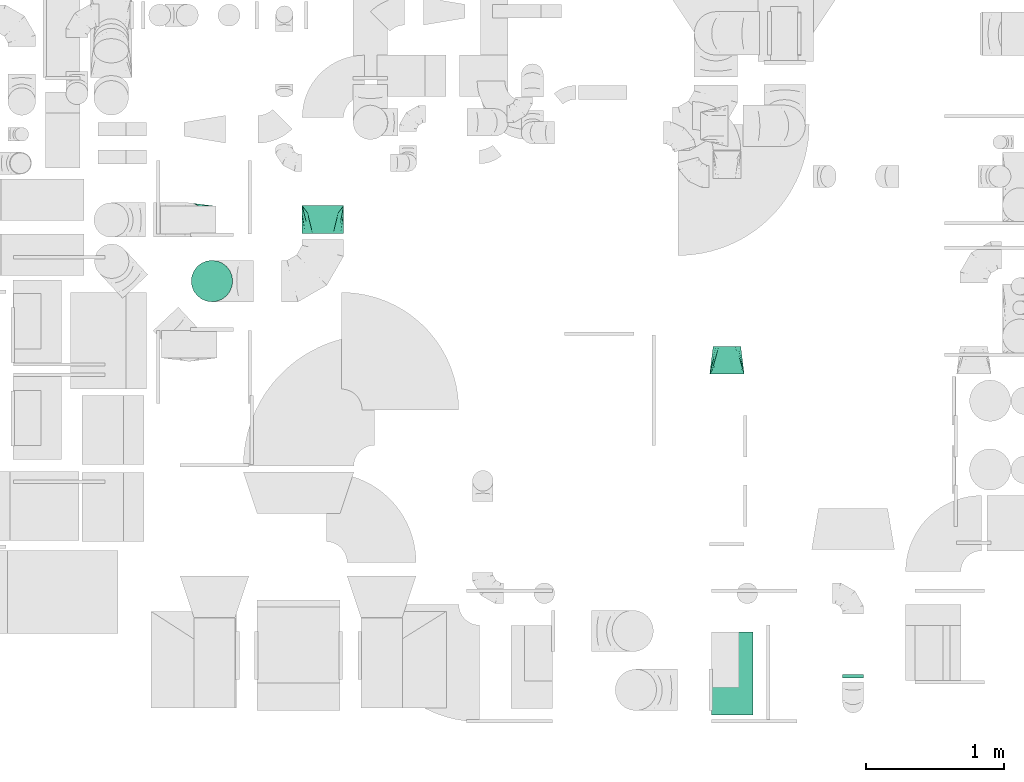
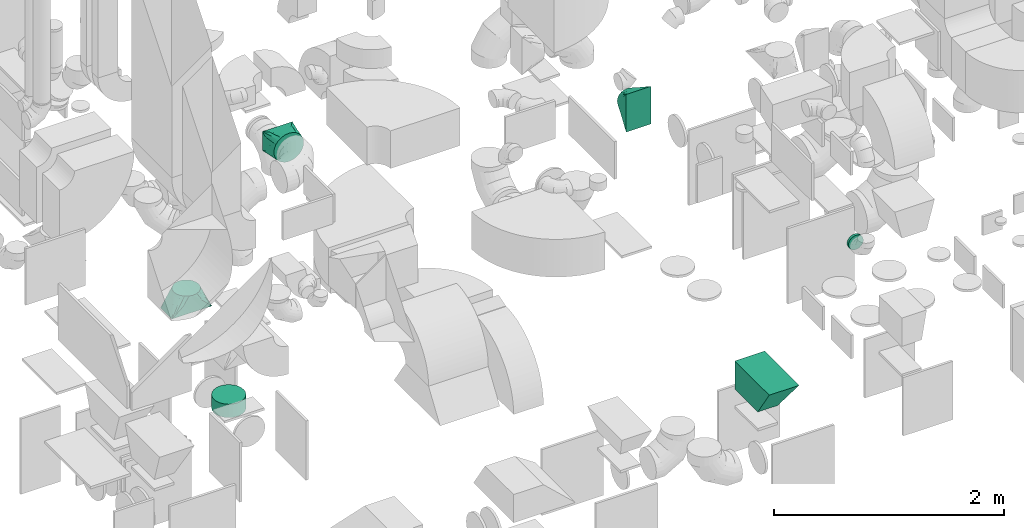
# One storey, part 54 of 59: 6 flow fittings.
"""IFC2X3 building model written with IfcOpenShell, lengths in millimetres."""

from ifc_helpers import new_model, entity, si_unit, converted_unit, derived_unit, direction, frame, origin, place, context, subcontext, project, spatial, faceted_brep, source, transform, mapped, material, type_object, type_shapes, element, save


model = new_model("IFC2X3")

# Units and contexts
model_context = context("Model", 3, precision=0.01, world=origin(), true_north=direction((6.12303176911189e-17, 1.0)))
body_context = subcontext(model_context, "Body", "Model", "MODEL_VIEW")
ifc_project = project(units=[si_unit("LENGTHUNIT", "METRE", prefix="MILLI"), si_unit("AREAUNIT", "SQUARE_METRE"), si_unit("VOLUMEUNIT", "CUBIC_METRE"), converted_unit("PLANEANGLEUNIT", "DEGREE", entity("IfcRatioMeasure", 0.0174532925199433), si_unit("PLANEANGLEUNIT", "RADIAN"), dimensions=[0, 0, 0, 0, 0, 0, 0]), si_unit("MASSUNIT", "GRAM", prefix="KILO"), derived_unit("MASSDENSITYUNIT", [(si_unit("MASSUNIT", "GRAM", prefix="KILO"), 1), (si_unit("LENGTHUNIT", "METRE"), -3)]), derived_unit("MOMENTOFINERTIAUNIT", [(si_unit("LENGTHUNIT", "METRE"), 4)]), si_unit("TIMEUNIT", "SECOND"), si_unit("FREQUENCYUNIT", "HERTZ"), si_unit("THERMODYNAMICTEMPERATUREUNIT", "DEGREE_CELSIUS"), derived_unit("THERMALTRANSMITTANCEUNIT", [(si_unit("MASSUNIT", "GRAM", prefix="KILO"), 1), (si_unit("THERMODYNAMICTEMPERATUREUNIT", "KELVIN"), -1), (si_unit("TIMEUNIT", "SECOND"), -3)]), derived_unit("VOLUMETRICFLOWRATEUNIT", [(si_unit("LENGTHUNIT", "METRE"), 3), (si_unit("TIMEUNIT", "SECOND"), -1)]), derived_unit("MASSFLOWRATEUNIT", [(si_unit("MASSUNIT", "GRAM", prefix="KILO"), 1), (si_unit("TIMEUNIT", "SECOND"), -1)]), derived_unit("ROTATIONALFREQUENCYUNIT", [(si_unit("TIMEUNIT", "SECOND"), -1)]), si_unit("ELECTRICCURRENTUNIT", "AMPERE"), si_unit("ELECTRICVOLTAGEUNIT", "VOLT"), si_unit("POWERUNIT", "WATT"), si_unit("FORCEUNIT", "NEWTON", prefix="KILO"), si_unit("ILLUMINANCEUNIT", "LUX"), si_unit("LUMINOUSFLUXUNIT", "LUMEN"), si_unit("LUMINOUSINTENSITYUNIT", "CANDELA"), derived_unit("USERDEFINED", [(si_unit("MASSUNIT", "GRAM", prefix="KILO"), -1), (si_unit("LENGTHUNIT", "METRE"), -2), (si_unit("TIMEUNIT", "SECOND"), 3), (si_unit("LUMINOUSFLUXUNIT", "LUMEN"), 1)]), derived_unit("LINEARVELOCITYUNIT", [(si_unit("LENGTHUNIT", "METRE"), 1), (si_unit("TIMEUNIT", "SECOND"), -1)]), si_unit("PRESSUREUNIT", "PASCAL"), derived_unit("USERDEFINED", [(si_unit("LENGTHUNIT", "METRE"), -2), (si_unit("MASSUNIT", "GRAM", prefix="KILO"), 1), (si_unit("TIMEUNIT", "SECOND"), -2)]), derived_unit("LINEARFORCEUNIT", [(si_unit("MASSUNIT", "GRAM", prefix="KILO"), 1), (si_unit("LENGTHUNIT", "METRE"), 1), (si_unit("TIMEUNIT", "SECOND"), -2), (si_unit("LENGTHUNIT", "METRE"), -1)]), derived_unit("PLANARFORCEUNIT", [(si_unit("MASSUNIT", "GRAM", prefix="KILO"), 1), (si_unit("LENGTHUNIT", "METRE"), 1), (si_unit("TIMEUNIT", "SECOND"), -2), (si_unit("LENGTHUNIT", "METRE"), -2)])], contexts=[model_context])

# Site, building, storey
site_placement = place(None, origin())
site = spatial("IfcSite", under=ifc_project, at=site_placement, CompositionType="ELEMENT")
building_placement = place(site_placement, origin())
building = spatial("IfcBuilding", under=site, at=building_placement, CompositionType="ELEMENT")
storey_placement = place(building_placement, frame((0.0, 0.0, 28200.0)))
storey = spatial("IfcBuildingStorey", under=building, at=storey_placement, CompositionType="ELEMENT", Elevation=28200.0)

# Flow fittings
ifc_material = material()
duct_fitting_type_1 = type_object("IfcDuctFittingType", PredefinedType="NOTDEFINED", material=ifc_material)
shared_shape_1 = source(origin(), body_context, "Body", "Brep", [
    faceted_brep([(200.0, 73.47, 101.13), (200.0, 56.05, 110.0), (200.0, 38.63, 118.88), (200.0, 23.84, 121.22), (200.0, 11.92, 123.11), (200.0, 5.96, 124.06), (200.0, 0.0, 125.0), (200.0, -5.96, 124.06), (200.0, -11.92, 123.11), (200.0, -23.84, 121.22), (200.0, -38.63, 118.88), (200.0, -56.05, 110.0), (200.0, -73.47, 101.13), (200.0, -87.3, 87.3), (200.0, -101.13, 73.47), (200.0, -110.0, 56.05), (200.0, -118.88, 38.63), (200.0, -121.22, 23.84), (200.0, -123.11, 11.92), (200.0, -124.06, 5.96), (200.0, -125.0, 0.0), (200.0, -124.06, -5.96), (200.0, -123.11, -11.92), (200.0, -121.22, -23.84), (200.0, -118.88, -38.63), (200.0, -110.0, -56.05), (200.0, -101.13, -73.47), (200.0, -87.3, -87.3), (200.0, -73.47, -101.13), (200.0, -56.05, -110.0), (200.0, -38.63, -118.88), (200.0, -23.84, -121.22), (200.0, -11.92, -123.11), (200.0, -5.96, -124.06), (200.0, 0.0, -125.0), (200.0, 5.96, -124.06), (200.0, 11.92, -123.11), (200.0, 23.84, -121.22), (200.0, 38.63, -118.88), (200.0, 56.05, -110.0), (200.0, 73.47, -101.13), (200.0, 87.3, -87.3), (200.0, 101.13, -73.47), (200.0, 110.0, -56.05), (200.0, 118.88, -38.63), (200.0, 121.22, -23.84), (200.0, 123.11, -11.92), (200.0, 124.06, -5.96), (200.0, 125.0, 0.0), (200.0, 124.06, 5.96), (200.0, 123.11, 11.92), (200.0, 121.22, 23.84), (200.0, 118.88, 38.63), (200.0, 110.0, 56.05), (200.0, 101.13, 73.47), (200.0, 87.3, 87.3), (0.0, -100.0, 200.0), (0.0, 100.0, 200.0), (0.0, 100.0, -200.0), (0.0, -100.0, -200.0), (104.11, -47.94, 160.96), (100.0, -91.44, 146.79), (26.03, -86.99, 190.24), (78.09, -60.96, 170.72), (52.06, -73.97, 180.48), (188.01, -5.99, 129.49), (176.03, -11.99, 133.99), (152.06, -23.97, 142.98), (128.09, -35.96, 151.97), (52.06, -106.51, 147.94), (78.09, -109.76, 121.91), (104.11, -113.01, 95.89), (128.09, -116.01, 71.91), (152.06, -119.01, 47.94), (176.03, -122.0, 23.97), (188.01, -123.5, 11.99), (26.03, -103.25, 173.97), (26.03, -103.25, -173.97), (52.06, -106.51, -147.94), (78.09, -109.76, -121.91), (104.11, -113.01, -95.89), (128.09, -116.01, -71.91), (152.06, -119.01, -47.94), (176.03, -122.0, -23.97), (188.01, -123.5, -11.99), (100.0, -96.79, -141.44), (52.06, -73.97, -180.48), (78.09, -60.96, -170.72), (104.11, -47.94, -160.96), (128.09, -35.96, -151.97), (152.06, -23.97, -142.98), (176.03, -11.99, -133.99), (188.01, -5.99, -129.49), (26.03, -86.99, -190.24), (26.03, 86.99, -190.24), (52.06, 73.97, -180.48), (78.09, 60.96, -170.72), (104.11, 47.94, -160.96), (128.09, 35.96, -151.97), (152.06, 23.97, -142.98), (176.03, 11.99, -133.99), (188.01, 5.99, -129.49), (100.0, 91.44, -146.79), (52.06, 106.51, -147.94), (78.09, 109.76, -121.91), (104.11, 113.01, -95.89), (128.09, 116.01, -71.91), (152.06, 119.01, -47.94), (176.03, 122.0, -23.97), (188.01, 123.5, -11.99), (26.03, 103.25, -173.97), (26.03, 103.25, 173.97), (52.06, 106.51, 147.94), (78.09, 109.76, 121.91), (104.11, 113.01, 95.89), (128.09, 116.01, 71.91), (152.06, 119.01, 47.94), (176.03, 122.0, 23.97), (188.01, 123.5, 11.99), (100.0, 96.79, 141.44), (52.06, 73.97, 180.48), (78.09, 60.96, 170.72), (104.11, 47.94, 160.96), (128.09, 35.96, 151.97), (152.06, 23.97, 142.98), (176.03, 11.99, 133.99), (188.01, 5.99, 129.49), (26.03, 86.99, 190.24)], [[[0, 1, 2, 3, 4, 5, 6, 7, 8, 9, 10, 11, 12, 13, 14, 15, 16, 17, 18, 19, 20, 21, 22, 23, 24, 25, 26, 27, 28, 29, 30, 31, 32, 33, 34, 35, 36, 37, 38, 39, 40, 41, 42, 43, 44, 45, 46, 47, 48, 49, 50, 51, 52, 53, 54, 55]], [[56, 57, 58, 59]], [[60, 11, 10]], [[56, 61, 62]], [[11, 60, 63, 64]], [[65, 66, 67, 68, 60, 10, 9, 8, 7, 6]], [[62, 61, 12]], [[15, 69, 70, 71]], [[64, 12, 11]], [[16, 71, 72, 73, 74, 75, 20, 19, 18, 17]], [[14, 76, 69]], [[71, 16, 15]], [[61, 76, 13]], [[12, 64, 62]], [[76, 14, 13]], [[12, 61, 13]], [[61, 56, 76]], [[69, 15, 14]], [[75, 74, 73, 72, 71, 70, 69, 76, 56, 59, 77, 78, 79, 80, 81, 82, 83, 84, 20]], [[80, 25, 24]], [[59, 85, 77]], [[25, 80, 79, 78]], [[84, 83, 82, 81, 80, 24, 23, 22, 21, 20]], [[77, 85, 26]], [[29, 86, 87, 88]], [[78, 26, 25]], [[30, 88, 89, 90, 91, 92, 34, 33, 32, 31]], [[28, 93, 86]], [[88, 30, 29]], [[85, 93, 27]], [[26, 78, 77]], [[93, 28, 27]], [[26, 85, 27]], [[85, 59, 93]], [[86, 29, 28]], [[92, 91, 90, 89, 88, 87, 86, 93, 59, 58, 94, 95, 96, 97, 98, 99, 100, 101, 34]], [[97, 39, 38]], [[58, 102, 94]], [[39, 97, 96, 95]], [[101, 100, 99, 98, 97, 38, 37, 36, 35, 34]], [[94, 102, 40]], [[43, 103, 104, 105]], [[95, 40, 39]], [[44, 105, 106, 107, 108, 109, 48, 47, 46, 45]], [[42, 110, 103]], [[105, 44, 43]], [[102, 110, 41]], [[40, 95, 94]], [[110, 42, 41]], [[40, 102, 41]], [[102, 58, 110]], [[103, 43, 42]], [[58, 57, 111, 112, 113, 114, 115, 116, 117, 118, 48, 109, 108, 107, 106, 105, 104, 103, 110]], [[114, 53, 52]], [[57, 119, 111]], [[53, 114, 113, 112]], [[118, 117, 116, 115, 114, 52, 51, 50, 49, 48]], [[111, 119, 54]], [[1, 120, 121, 122]], [[112, 54, 53]], [[2, 122, 123, 124, 125, 126, 6, 5, 4, 3]], [[0, 127, 120]], [[122, 2, 1]], [[119, 127, 55]], [[54, 112, 111]], [[127, 0, 55]], [[54, 119, 55]], [[119, 57, 127]], [[120, 1, 0]], [[57, 56, 62, 64, 63, 60, 68, 67, 66, 65, 6, 126, 125, 124, 123, 122, 121, 120, 127]]]),
])
type_shapes(duct_fitting_type_1, [shared_shape_1])
flow_fitting_1_placement = place(storey_placement, frame((49574.88, 11542.75, 1490.0), z_axis=(1.0, 0.0, 0.0), x_axis=(0.0, 0.0, 1.0)))
element("IfcFlowFitting", 1, at=flow_fitting_1_placement, inside=storey, type_object=duct_fitting_type_1, material=ifc_material, context=body_context, shape_type="MappedRepresentation", body=[
    mapped(shared_shape_1, transform((0.0, 0.0, 0.0), scale=1.0)),
])
duct_fitting_type_2 = type_object("IfcDuctFittingType", PredefinedType="NOTDEFINED", material=ifc_material)
shared_shape_2 = source(origin(), body_context, "Body", "Brep", [
    faceted_brep([(20.0, 0.0, -150.0), (20.0, 38.82, -144.89), (20.0, 75.0, -129.9), (20.0, 106.07, -106.07), (20.0, 129.9, -75.0), (20.0, 144.89, -38.82), (20.0, 150.0, 0.0), (20.0, 144.89, 38.82), (20.0, 129.9, 75.0), (20.0, 106.07, 106.07), (20.0, 75.0, 129.9), (20.0, 38.82, 144.89), (20.0, 0.0, 150.0), (20.0, -38.82, 144.89), (20.0, -75.0, 129.9), (20.0, -106.07, 106.07), (20.0, -129.9, 75.0), (20.0, -144.89, 38.82), (20.0, -150.0, 0.0), (20.0, -144.89, -38.82), (20.0, -129.9, -75.0), (20.0, -106.07, -106.07), (20.0, -75.0, -129.9), (20.0, -38.82, -144.89), (0.0, 0.0, 150.0), (-122.04, 0.0, 150.0), (-122.04, -38.82, 144.89), (0.0, -38.82, 144.89), (-122.04, -75.0, 129.9), (0.0, -75.0, 129.9), (0.0, -106.07, 106.07), (-122.04, -106.07, 106.07), (0.0, -129.9, 75.0), (-122.04, -129.9, 75.0), (-122.04, -144.89, 38.82), (0.0, -144.89, 38.82), (-122.04, -150.0, 0.0), (0.0, -150.0, 0.0), (-122.04, -144.89, -38.82), (0.0, -144.89, -38.82), (-122.04, -129.9, -75.0), (0.0, -129.9, -75.0), (0.0, -106.07, -106.07), (-122.04, -106.07, -106.07), (0.0, -75.0, -129.9), (-122.04, -75.0, -129.9), (-122.04, -38.82, -144.89), (0.0, -38.82, -144.89), (-122.04, 0.0, -150.0), (0.0, 0.0, -150.0), (-122.04, 38.82, -144.89), (0.0, 38.82, -144.89), (-122.04, 75.0, -129.9), (0.0, 75.0, -129.9), (0.0, 106.07, -106.07), (-122.04, 106.07, -106.07), (0.0, 129.9, -75.0), (-122.04, 129.9, -75.0), (-122.04, 144.89, -38.82), (0.0, 144.89, -38.82), (-122.04, 150.0, 0.0), (0.0, 150.0, 0.0), (-122.04, 144.89, 38.82), (0.0, 144.89, 38.82), (-122.04, 129.9, 75.0), (0.0, 129.9, 75.0), (0.0, 106.07, 106.07), (-122.04, 106.07, 106.07), (0.0, 75.0, 129.9), (-122.04, 75.0, 129.9), (-122.04, 38.82, 144.89), (0.0, 38.82, 144.89)], [[[0, 1, 2, 3, 4, 5, 6, 7, 8, 9, 10, 11, 12, 13, 14, 15, 16, 17, 18, 19, 20, 21, 22, 23]], [[13, 12, 24, 25, 26, 27]], [[14, 13, 27, 26, 28, 29]], [[30, 15, 14, 29, 28, 31]], [[17, 16, 32, 33, 34, 35]], [[18, 17, 35, 34, 36, 37]], [[32, 16, 15, 30, 31, 33]], [[19, 18, 37, 36, 38, 39]], [[20, 19, 39, 38, 40, 41]], [[42, 21, 20, 41, 40, 43]], [[23, 22, 44, 45, 46, 47]], [[0, 23, 47, 46, 48, 49]], [[44, 22, 21, 42, 43, 45]], [[1, 0, 49, 48, 50, 51]], [[2, 1, 51, 50, 52, 53]], [[54, 3, 2, 53, 52, 55]], [[5, 4, 56, 57, 58, 59]], [[6, 5, 59, 58, 60, 61]], [[56, 4, 3, 54, 55, 57]], [[7, 6, 61, 60, 62, 63]], [[8, 7, 63, 62, 64, 65]], [[66, 9, 8, 65, 64, 67]], [[11, 10, 68, 69, 70, 71]], [[12, 11, 71, 70, 25, 24]], [[68, 10, 9, 66, 67, 69]], [[46, 45, 43, 40, 38, 36, 34, 33, 31, 28, 26, 25, 70, 69, 67, 64, 62, 60, 58, 57, 55, 52, 50, 48]]]),
])
type_shapes(duct_fitting_type_2, [shared_shape_2])
flow_fitting_2_placement = place(storey_placement, frame((49746.88, 11100.25, 747.5), z_axis=(0.0, 1.0, 0.0), x_axis=(0.0, 0.0, 1.0)))
element("IfcFlowFitting", 2, at=flow_fitting_2_placement, inside=storey, type_object=duct_fitting_type_2, material=ifc_material, context=body_context, shape_type="MappedRepresentation", body=[
    mapped(shared_shape_2, transform((0.0, 0.0, 0.0), scale=1.0)),
])
duct_fitting_type_3 = type_object("IfcDuctFittingType", PredefinedType="NOTDEFINED", material=ifc_material)
shared_shape_3 = source(origin(), body_context, "Body", "Brep", [
    faceted_brep([(200.0, 75.0, 129.9), (200.0, 56.91, 137.4), (200.0, 38.82, 144.89), (200.0, 26.6, 146.5), (200.0, 14.38, 148.11), (200.0, 0.0, 150.0), (200.0, -14.38, 148.11), (200.0, -26.6, 146.5), (200.0, -38.82, 144.89), (200.0, -56.91, 137.4), (200.0, -75.0, 129.9), (200.0, -90.53, 117.98), (200.0, -106.07, 106.07), (200.0, -117.98, 90.53), (200.0, -129.9, 75.0), (200.0, -137.4, 56.91), (200.0, -144.89, 38.82), (200.0, -146.5, 26.6), (200.0, -148.11, 14.38), (200.0, -150.0, 0.0), (200.0, -148.11, -14.38), (200.0, -146.5, -26.6), (200.0, -144.89, -38.82), (200.0, -137.4, -56.91), (200.0, -129.9, -75.0), (200.0, -117.98, -90.53), (200.0, -106.07, -106.07), (200.0, -90.53, -117.98), (200.0, -75.0, -129.9), (200.0, -56.91, -137.4), (200.0, -38.82, -144.89), (200.0, -26.6, -146.5), (200.0, -14.38, -148.11), (200.0, 0.0, -150.0), (200.0, 14.38, -148.11), (200.0, 26.6, -146.5), (200.0, 38.82, -144.89), (200.0, 56.91, -137.4), (200.0, 75.0, -129.9), (200.0, 90.53, -117.98), (200.0, 106.07, -106.07), (200.0, 117.98, -90.53), (200.0, 129.9, -75.0), (200.0, 137.4, -56.91), (200.0, 144.89, -38.82), (200.0, 146.5, -26.6), (200.0, 148.11, -14.38), (200.0, 150.0, 0.0), (200.0, 148.11, 14.38), (200.0, 146.5, 26.6), (200.0, 144.89, 38.82), (200.0, 137.4, 56.91), (200.0, 129.9, 75.0), (200.0, 117.98, 90.53), (200.0, 106.07, 106.07), (200.0, 90.53, 117.98), (0.0, -150.0, 100.0), (0.0, 150.0, 100.0), (0.0, 150.0, -100.0), (0.0, -150.0, -100.0), (128.09, -53.94, 132.02), (104.11, -71.91, 126.03), (78.09, -91.44, 119.52), (100.0, -124.73, 106.15), (26.03, -130.48, 106.51), (52.06, -150.0, 73.97), (26.03, -150.0, 86.99), (78.09, -150.0, 60.96), (104.11, -150.0, 47.94), (128.09, -150.0, 35.96), (176.03, -17.98, 144.01), (152.06, -35.96, 138.01), (152.06, -150.0, 23.97), (176.03, -150.0, 11.99), (52.06, -110.96, 113.01), (26.03, -150.0, -86.99), (52.06, -150.0, -73.97), (78.09, -150.0, -60.96), (104.11, -150.0, -47.94), (128.09, -150.0, -35.96), (152.06, -150.0, -23.97), (176.03, -150.0, -11.99), (100.0, -131.15, -99.73), (52.06, -110.96, -113.01), (26.03, -130.48, -106.51), (78.09, -91.44, -119.52), (104.11, -71.91, -126.03), (128.09, -53.94, -132.02), (152.06, -35.96, -138.01), (176.03, -17.98, -144.01), (26.03, 130.48, -106.51), (52.06, 110.96, -113.01), (78.09, 91.44, -119.52), (104.11, 71.91, -126.03), (128.09, 53.94, -132.02), (152.06, 35.96, -138.01), (176.03, 17.98, -144.01), (100.0, 124.73, -106.15), (52.06, 150.0, -73.97), (26.03, 150.0, -86.99), (78.09, 150.0, -60.96), (104.11, 150.0, -47.94), (128.09, 150.0, -35.96), (152.06, 150.0, -23.97), (176.03, 150.0, -11.99), (26.03, 150.0, 86.99), (52.06, 150.0, 73.97), (78.09, 150.0, 60.96), (104.11, 150.0, 47.94), (128.09, 150.0, 35.96), (152.06, 150.0, 23.97), (176.03, 150.0, 11.99), (100.0, 131.15, 99.73), (52.06, 110.96, 113.01), (26.03, 130.48, 106.51), (78.09, 91.44, 119.52), (104.11, 71.91, 126.03), (128.09, 53.94, 132.02), (152.06, 35.96, 138.01), (176.03, 17.98, 144.01)], [[[0, 1, 2, 3, 4, 5, 6, 7, 8, 9, 10, 11, 12, 13, 14, 15, 16, 17, 18, 19, 20, 21, 22, 23, 24, 25, 26, 27, 28, 29, 30, 31, 32, 33, 34, 35, 36, 37, 38, 39, 40, 41, 42, 43, 44, 45, 46, 47, 48, 49, 50, 51, 52, 53, 54, 55]], [[56, 57, 58, 59]], [[60, 61, 62, 9]], [[63, 11, 64]], [[13, 12, 63]], [[8, 60, 9]], [[9, 62, 10]], [[65, 14, 13]], [[13, 63, 66]], [[15, 67, 68, 69]], [[70, 71, 60, 8, 7, 6, 5]], [[17, 16, 69, 72, 73, 19, 18]], [[15, 14, 67]], [[15, 69, 16]], [[14, 65, 67]], [[11, 74, 64]], [[11, 10, 74]], [[56, 63, 64]], [[11, 63, 12]], [[13, 66, 65]], [[63, 56, 66]], [[62, 74, 10]], [[73, 72, 69, 68, 67, 65, 66, 56, 59, 75, 76, 77, 78, 79, 80, 81, 19]], [[79, 78, 77, 23]], [[82, 25, 75]], [[27, 26, 82]], [[22, 79, 23]], [[23, 77, 24]], [[83, 28, 27]], [[27, 82, 84]], [[29, 85, 86, 87]], [[81, 80, 79, 22, 21, 20, 19]], [[31, 30, 87, 88, 89, 33, 32]], [[29, 28, 85]], [[29, 87, 30]], [[28, 83, 85]], [[25, 76, 75]], [[25, 24, 76]], [[59, 82, 75]], [[25, 82, 26]], [[27, 84, 83]], [[82, 59, 84]], [[77, 76, 24]], [[89, 88, 87, 86, 85, 83, 84, 59, 58, 90, 91, 92, 93, 94, 95, 96, 33]], [[94, 93, 92, 37]], [[97, 39, 90]], [[41, 40, 97]], [[36, 94, 37]], [[37, 92, 38]], [[98, 42, 41]], [[41, 97, 99]], [[43, 100, 101, 102]], [[96, 95, 94, 36, 35, 34, 33]], [[45, 44, 102, 103, 104, 47, 46]], [[43, 42, 100]], [[43, 102, 44]], [[42, 98, 100]], [[39, 91, 90]], [[39, 38, 91]], [[58, 97, 90]], [[39, 97, 40]], [[41, 99, 98]], [[97, 58, 99]], [[92, 91, 38]], [[58, 57, 105, 106, 107, 108, 109, 110, 111, 47, 104, 103, 102, 101, 100, 98, 99]], [[109, 108, 107, 51]], [[112, 53, 105]], [[55, 54, 112]], [[50, 109, 51]], [[51, 107, 52]], [[113, 0, 55]], [[55, 112, 114]], [[1, 115, 116, 117]], [[111, 110, 109, 50, 49, 48, 47]], [[3, 2, 117, 118, 119, 5, 4]], [[1, 0, 115]], [[1, 117, 2]], [[0, 113, 115]], [[53, 106, 105]], [[53, 52, 106]], [[57, 112, 105]], [[53, 112, 54]], [[55, 114, 113]], [[112, 57, 114]], [[107, 106, 52]], [[57, 56, 64, 74, 62, 61, 60, 71, 70, 5, 119, 118, 117, 116, 115, 113, 114]]]),
])
type_shapes(duct_fitting_type_3, [shared_shape_3])
flow_fitting_3_placement = place(storey_placement, frame((50549.86, 11646.25, 2900.0), z_axis=(0.0, 0.0, 1.0), x_axis=(0.0, -1.0, 0.0)))
element("IfcFlowFitting", 3, at=flow_fitting_3_placement, inside=storey, type_object=duct_fitting_type_3, material=ifc_material, context=body_context, shape_type="MappedRepresentation", body=[
    mapped(shared_shape_3, transform((0.0, 0.0, 0.0), scale=1.0)),
])
duct_fitting_type_4 = type_object("IfcDuctFittingType", PredefinedType="NOTDEFINED", material=ifc_material)
shared_shape_4 = source(origin(), body_context, "Body", "Brep", [
    faceted_brep([(300.0, 200.0, 200.0), (300.0, -100.0, 200.0), (300.0, -100.0, -400.0), (300.0, 200.0, -400.0), (0.0, 100.0, 200.0), (0.0, 100.0, -200.0), (0.0, -100.0, -200.0), (0.0, -100.0, 200.0)], [[[0, 1, 2, 3]], [[4, 5, 6, 7]], [[4, 0, 3, 5]], [[5, 3, 2, 6]], [[6, 2, 1, 7]], [[7, 1, 0, 4]]]),
])
type_shapes(duct_fitting_type_4, [shared_shape_4])
flow_fitting_4_placement = place(storey_placement, frame((53463.63, 8360.0, 1097.0), z_axis=(0.0, 1.0, 0.0), x_axis=(0.0, 0.0, 1.0)))
element("IfcFlowFitting", 4, at=flow_fitting_4_placement, inside=storey, type_object=duct_fitting_type_4, material=ifc_material, context=body_context, shape_type="MappedRepresentation", body=[
    mapped(shared_shape_4, transform((0.0, 0.0, 0.0), scale=1.0)),
])
duct_fitting_type_5 = type_object("IfcDuctFittingType", PredefinedType="NOTDEFINED", material=ifc_material)
shared_shape_5 = source(origin(), body_context, "Body", "Brep", [
    faceted_brep([(20.0, 19.41, -72.44), (20.0, 37.5, -64.95), (20.0, 53.03, -53.03), (20.0, 64.95, -37.5), (20.0, 72.44, -19.41), (20.0, 75.0, 0.0), (20.0, 72.44, 19.41), (20.0, 64.95, 37.5), (20.0, 53.03, 53.03), (20.0, 37.5, 64.95), (20.0, 19.41, 72.44), (20.0, 0.0, 75.0), (20.0, -19.41, 72.44), (20.0, -37.5, 64.95), (20.0, -53.03, 53.03), (20.0, -64.95, 37.5), (20.0, -72.44, 19.41), (20.0, -75.0, 0.0), (20.0, -72.44, -19.41), (20.0, -64.95, -37.5), (20.0, -53.03, -53.03), (20.0, -37.5, -64.95), (20.0, -19.41, -72.44), (20.0, 0.0, -75.0), (0.0, 0.0, 75.0), (0.0, 19.41, 72.44), (-6.1, 19.41, 72.44), (-6.1, 0.0, 75.0), (0.0, 37.5, 64.95), (-6.1, 37.5, 64.95), (0.0, 53.03, 53.03), (-6.1, 53.03, 53.03), (0.0, 64.95, 37.5), (0.0, 72.44, 19.41), (-6.1, 72.44, 19.41), (-6.1, 64.95, 37.5), (0.0, 75.0, 0.0), (-6.1, 75.0, 0.0), (0.0, 72.44, -19.41), (-6.1, 72.44, -19.41), (0.0, 64.95, -37.5), (-6.1, 64.95, -37.5), (0.0, 53.03, -53.03), (-6.1, 53.03, -53.03), (0.0, 37.5, -64.95), (0.0, 19.41, -72.44), (-6.1, 19.41, -72.44), (-6.1, 37.5, -64.95), (0.0, 0.0, -75.0), (-6.1, 0.0, -75.0), (0.0, -19.41, -72.44), (-6.1, -19.41, -72.44), (0.0, -37.5, -64.95), (-6.1, -37.5, -64.95), (0.0, -53.03, -53.03), (-6.1, -53.03, -53.03), (0.0, -64.95, -37.5), (0.0, -72.44, -19.41), (-6.1, -72.44, -19.41), (-6.1, -64.95, -37.5), (0.0, -75.0, 0.0), (-6.1, -75.0, 0.0), (0.0, -72.44, 19.41), (-6.1, -72.44, 19.41), (0.0, -64.95, 37.5), (-6.1, -64.95, 37.5), (0.0, -53.03, 53.03), (-6.1, -53.03, 53.03), (0.0, -37.5, 64.95), (0.0, -19.41, 72.44), (-6.1, -19.41, 72.44), (-6.1, -37.5, 64.95)], [[[0, 1, 2, 3, 4, 5, 6, 7, 8, 9, 10, 11, 12, 13, 14, 15, 16, 17, 18, 19, 20, 21, 22, 23]], [[24, 11, 10, 25, 26, 27]], [[25, 10, 9, 28, 29, 26]], [[28, 9, 8, 30, 31, 29]], [[32, 7, 6, 33, 34, 35]], [[33, 6, 5, 36, 37, 34]], [[30, 8, 7, 32, 35, 31]], [[36, 5, 4, 38, 39, 37]], [[38, 4, 3, 40, 41, 39]], [[40, 3, 2, 42, 43, 41]], [[44, 1, 0, 45, 46, 47]], [[48, 49, 46, 45, 0, 23]], [[42, 2, 1, 44, 47, 43]], [[48, 23, 22, 50, 51, 49]], [[50, 22, 21, 52, 53, 51]], [[52, 21, 20, 54, 55, 53]], [[56, 19, 18, 57, 58, 59]], [[57, 18, 17, 60, 61, 58]], [[54, 20, 19, 56, 59, 55]], [[60, 17, 16, 62, 63, 61]], [[62, 16, 15, 64, 65, 63]], [[64, 15, 14, 66, 67, 65]], [[68, 13, 12, 69, 70, 71]], [[69, 12, 11, 24, 27, 70]], [[66, 14, 13, 68, 71, 67]], [[49, 51, 53, 55, 59, 58, 61, 63, 65, 67, 71, 70, 27, 26, 29, 31, 35, 34, 37, 39, 41, 43, 47, 46]]]),
])
type_shapes(duct_fitting_type_5, [shared_shape_5])
flow_fitting_5_placement = place(storey_placement, frame((54388.0, 8245.5, 2500.0), z_axis=(-1.0, 0.0, 0.0), x_axis=(0.0, -1.0, 0.0)))
element("IfcFlowFitting", 5, at=flow_fitting_5_placement, inside=storey, type_object=duct_fitting_type_5, material=ifc_material, context=body_context, shape_type="MappedRepresentation", body=[
    mapped(shared_shape_5, transform((0.0, 0.0, 0.0), scale=1.0)),
])
duct_fitting_type_6 = type_object("IfcDuctFittingType", PredefinedType="NOTDEFINED", material=ifc_material)
shared_shape_6 = source(origin(), body_context, "Body", "Brep", [
    faceted_brep([(200.0, -30.9, -95.11), (200.0, -19.08, -96.98), (200.0, -9.54, -98.49), (200.0, -4.77, -99.24), (200.0, 0.0, -100.0), (200.0, 4.77, -99.24), (200.0, 9.54, -98.49), (200.0, 19.08, -96.98), (200.0, 30.9, -95.11), (200.0, 44.84, -88.0), (200.0, 58.78, -80.9), (200.0, 69.84, -69.84), (200.0, 80.9, -58.78), (200.0, 88.0, -44.84), (200.0, 95.11, -30.9), (200.0, 96.98, -19.08), (200.0, 98.49, -9.54), (200.0, 99.24, -4.77), (200.0, 100.0, 0.0), (200.0, 99.24, 4.77), (200.0, 98.49, 9.54), (200.0, 96.98, 19.08), (200.0, 95.11, 30.9), (200.0, 88.0, 44.84), (200.0, 80.9, 58.78), (200.0, 69.84, 69.84), (200.0, 58.78, 80.9), (200.0, 44.84, 88.0), (200.0, 30.9, 95.11), (200.0, 19.08, 96.98), (200.0, 9.54, 98.49), (200.0, 4.77, 99.24), (200.0, 0.0, 100.0), (200.0, -4.77, 99.24), (200.0, -9.54, 98.49), (200.0, -19.08, 96.98), (200.0, -30.9, 95.11), (200.0, -44.84, 88.0), (200.0, -58.78, 80.9), (200.0, -69.84, 69.84), (200.0, -80.9, 58.78), (200.0, -88.0, 44.84), (200.0, -95.11, 30.9), (200.0, -96.98, 19.08), (200.0, -98.49, 9.54), (200.0, -99.24, 4.77), (200.0, -100.0, 0.0), (200.0, -99.24, -4.77), (200.0, -98.49, -9.54), (200.0, -96.98, -19.08), (200.0, -95.11, -30.9), (200.0, -88.0, -44.84), (200.0, -80.9, -58.78), (200.0, -69.84, -69.84), (200.0, -58.78, -80.9), (200.0, -44.84, -88.0), (0.0, -125.0, 200.0), (0.0, 125.0, 200.0), (0.0, 125.0, -200.0), (0.0, -125.0, -200.0), (104.11, -59.93, 147.94), (100.0, -95.65, 137.43), (26.03, -108.73, 186.99), (78.09, -76.2, 160.96), (52.06, -92.46, 173.97), (188.01, -7.49, 105.99), (176.03, -14.98, 111.99), (152.06, -29.96, 123.97), (128.09, -44.95, 135.96), (52.06, -118.49, 147.94), (78.09, -115.24, 121.91), (104.11, -111.99, 95.89), (128.09, -108.99, 71.91), (152.06, -105.99, 47.94), (176.03, -103.0, 23.97), (188.01, -101.5, 11.99), (26.03, -121.75, 173.97), (26.03, -121.75, -173.97), (52.06, -118.49, -147.94), (78.09, -115.24, -121.91), (104.11, -111.99, -95.89), (128.09, -108.99, -71.91), (152.06, -105.99, -47.94), (176.03, -103.0, -23.97), (188.01, -101.5, -11.99), (100.0, -99.93, -133.15), (52.06, -92.46, -173.97), (78.09, -76.2, -160.96), (104.11, -59.93, -147.94), (128.09, -44.95, -135.96), (152.06, -29.96, -123.97), (176.03, -14.98, -111.99), (188.01, -7.49, -105.99), (26.03, -108.73, -186.99), (26.03, 108.73, -186.99), (52.06, 92.46, -173.97), (78.09, 76.2, -160.96), (104.11, 59.93, -147.94), (128.09, 44.95, -135.96), (152.06, 29.96, -123.97), (176.03, 14.98, -111.99), (188.01, 7.49, -105.99), (100.0, 95.65, -137.43), (52.06, 118.49, -147.94), (78.09, 115.24, -121.91), (104.11, 111.99, -95.89), (128.09, 108.99, -71.91), (152.06, 105.99, -47.94), (176.03, 103.0, -23.97), (188.01, 101.5, -11.99), (26.03, 121.75, -173.97), (26.03, 121.75, 173.97), (52.06, 118.49, 147.94), (78.09, 115.24, 121.91), (104.11, 111.99, 95.89), (128.09, 108.99, 71.91), (152.06, 105.99, 47.94), (176.03, 103.0, 23.97), (188.01, 101.5, 11.99), (100.0, 99.93, 133.15), (52.06, 92.46, 173.97), (78.09, 76.2, 160.96), (104.11, 59.93, 147.94), (128.09, 44.95, 135.96), (152.06, 29.96, 123.97), (176.03, 14.98, 111.99), (188.01, 7.49, 105.99), (26.03, 108.73, 186.99)], [[[0, 1, 2, 3, 4, 5, 6, 7, 8, 9, 10, 11, 12, 13, 14, 15, 16, 17, 18, 19, 20, 21, 22, 23, 24, 25, 26, 27, 28, 29, 30, 31, 32, 33, 34, 35, 36, 37, 38, 39, 40, 41, 42, 43, 44, 45, 46, 47, 48, 49, 50, 51, 52, 53, 54, 55]], [[56, 57, 58, 59]], [[60, 37, 36]], [[56, 61, 62]], [[37, 60, 63, 64]], [[65, 66, 67, 68, 60, 36, 35, 34, 33, 32]], [[62, 61, 38]], [[41, 69, 70, 71]], [[64, 38, 37]], [[42, 71, 72, 73, 74, 75, 46, 45, 44, 43]], [[40, 76, 69]], [[71, 42, 41]], [[61, 76, 39]], [[38, 64, 62]], [[76, 40, 39]], [[38, 61, 39]], [[61, 56, 76]], [[69, 41, 40]], [[75, 74, 73, 72, 71, 70, 69, 76, 56, 59, 77, 78, 79, 80, 81, 82, 83, 84, 46]], [[80, 51, 50]], [[59, 85, 77]], [[51, 80, 79, 78]], [[84, 83, 82, 81, 80, 50, 49, 48, 47, 46]], [[77, 85, 52]], [[55, 86, 87, 88]], [[78, 52, 51]], [[0, 88, 89, 90, 91, 92, 4, 3, 2, 1]], [[54, 93, 86]], [[88, 0, 55]], [[85, 93, 53]], [[52, 78, 77]], [[93, 54, 53]], [[52, 85, 53]], [[85, 59, 93]], [[86, 55, 54]], [[92, 91, 90, 89, 88, 87, 86, 93, 59, 58, 94, 95, 96, 97, 98, 99, 100, 101, 4]], [[97, 9, 8]], [[58, 102, 94]], [[9, 97, 96, 95]], [[101, 100, 99, 98, 97, 8, 7, 6, 5, 4]], [[94, 102, 10]], [[13, 103, 104, 105]], [[95, 10, 9]], [[14, 105, 106, 107, 108, 109, 18, 17, 16, 15]], [[12, 110, 103]], [[105, 14, 13]], [[102, 110, 11]], [[10, 95, 94]], [[110, 12, 11]], [[10, 102, 11]], [[102, 58, 110]], [[103, 13, 12]], [[58, 57, 111, 112, 113, 114, 115, 116, 117, 118, 18, 109, 108, 107, 106, 105, 104, 103, 110]], [[114, 23, 22]], [[57, 119, 111]], [[23, 114, 113, 112]], [[118, 117, 116, 115, 114, 22, 21, 20, 19, 18]], [[111, 119, 24]], [[27, 120, 121, 122]], [[112, 24, 23]], [[28, 122, 123, 124, 125, 126, 32, 31, 30, 29]], [[26, 127, 120]], [[122, 28, 27]], [[119, 127, 25]], [[24, 112, 111]], [[127, 26, 25]], [[24, 119, 25]], [[119, 57, 127]], [[120, 27, 26]], [[57, 56, 62, 64, 63, 60, 68, 67, 66, 65, 32, 126, 125, 124, 123, 122, 121, 120, 127]]]),
])
type_shapes(duct_fitting_type_6, [shared_shape_6])
flow_fitting_6_placement = place(storey_placement, frame((53475.03, 10426.24, 2900.0), z_axis=(0.0, 0.0, 1.0), x_axis=(0.0, 1.0, 0.0)))
element("IfcFlowFitting", 6, at=flow_fitting_6_placement, inside=storey, type_object=duct_fitting_type_6, material=ifc_material, context=body_context, shape_type="MappedRepresentation", body=[
    mapped(shared_shape_6, transform((0.0, 0.0, 0.0), scale=1.0)),
])

save(model, "model.ifc")
